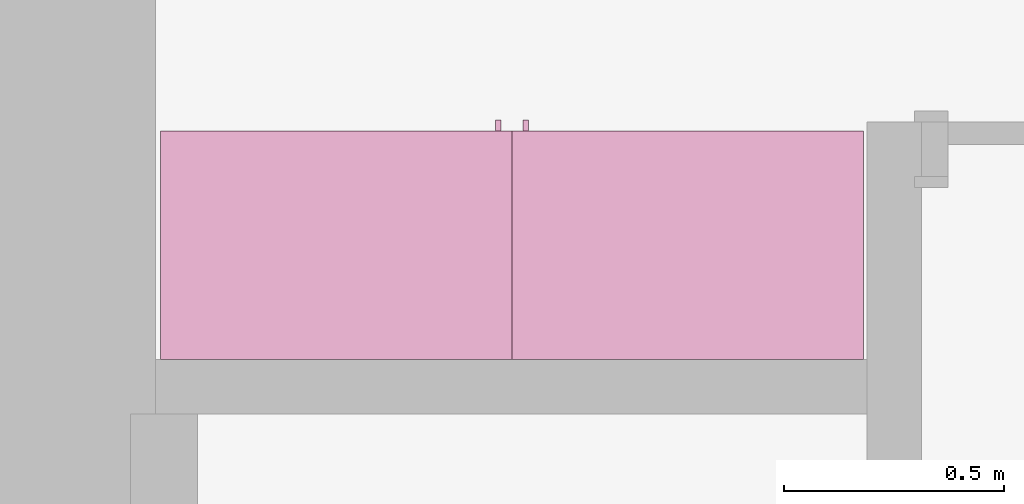
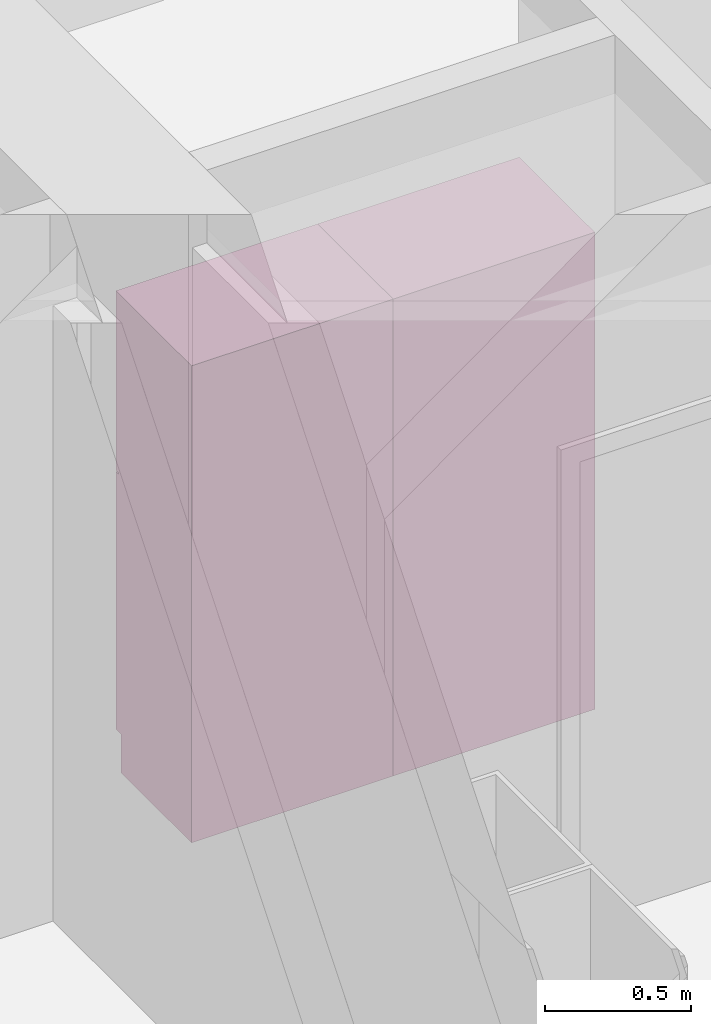
# One storey, part 16 of 16: 2 furnishings, 2 openings.
"""IFC2X3 building model written with IfcOpenShell, lengths in metres."""

from ifc_helpers import new_model, entity, si_unit, converted_unit, frame, origin, origin_2d_with_axis, place, context, project, spatial, rectangle, extrude, face_set, surface_model, source, transform, mapped, type_object, type_shapes, element, save


model = new_model("IFC2X3")

# Units and contexts
model_context = context("Model", 3, precision=1e-09, world=origin())
plan_context = context("Plan", 3, precision=1e-09, world=origin())
ifc_project = project(units=[si_unit("LENGTHUNIT", "METRE"), si_unit("AREAUNIT", "SQUARE_METRE"), si_unit("VOLUMEUNIT", "CUBIC_METRE"), converted_unit("PLANEANGLEUNIT", "DEGREE", entity("IfcRatioMeasure", 0.01745329251994328), si_unit("PLANEANGLEUNIT", "RADIAN"), dimensions=[0, 0, 0, 0, 0, 0, 0]), si_unit("TIMEUNIT", "SECOND")], contexts=[model_context, plan_context])

# Site, building, storey, space
site_placement = place(None, origin())
site = spatial("IfcSite", under=ifc_project, at=site_placement, CompositionType="ELEMENT")
building_placement = place(site_placement, origin())
building = spatial("IfcBuilding", under=site, at=building_placement, CompositionType="ELEMENT")
storey_placement = place(building_placement, frame((0.0, 0.0, 3.100000000000378)))
storey = spatial("IfcBuildingStorey", under=building, at=storey_placement, Name="Level 2", CompositionType="ELEMENT", Elevation=3.100000000000378)
space_placement = place(storey_placement, origin())
space = spatial("IfcSpace", under=storey, at=space_placement, CompositionType="ELEMENT", InteriorOrExteriorSpace="INTERNAL")

# Furnishing, opening
furniture_type_1 = type_object("IfcFurnitureType", Name="800 mm", AssemblyPlace="NOTDEFINED")
shared_shape_1 = source(origin(), model_context, "Body", "SurfaceModel", [
    surface_model("IfcFaceBasedSurfaceModel", [(0.7999999999999998, 0.04444999999999991, 0.1615874999998423), (0.0, 0.04445000000000255, 0.1615874999998423), (0.0, 0.04445000000000255, 2.0), (0.7999999999999998, 0.04444999999999991, 2.0), (0.7809499999999974, 0.04444999999999998, 1.980949999999954), (0.01904999999999817, 0.04445000000000248, 1.980949999999954), (0.01904999999999817, 0.04445000000000248, 0.1806374999998427), (0.7809499999999974, 0.04444999999999998, 0.1806374999998428), (0.0, 0.5454000000000022, 2.0), (0.8000000000000014, 0.5453999999999996, 2.0), (0.8000000000000026, 0.5453999999999996, 0.0), (0.0, 0.5454000000000009, 0.0), (0.780949999999999, 0.5453999999999996, 1.980949999999954), (0.0190499999999998, 0.5454000000000021, 1.980949999999954), (0.0190499999999998, 0.5454000000000021, 0.1806374999998428), (0.780949999999999, 0.5453999999999996, 0.1806374999998428), (0.7999999999999999, 0.06040000000000177, 0.1615874999998423), (0.7999999999999999, 0.06040000000000177, 0.0), (0.0, 0.06040000000000177, 0.0), (0.0, 0.06040000000000177, 0.1615874999998318), (0.7745999999999997, 0.0, 1.371548036695815), (0.7745999999999997, 0.0, 1.269948036695815), (0.7620677683693553, 0.0, 1.269948036695815), (0.7620677683693553, 0.0, 1.371548036695815), (0.7745999999999988, 0.0, 1.219148036695816), (0.7745999999999988, 0.0, 1.117548036695818), (0.7620677683693542, 0.0, 1.117548036695818), (0.7620677683693542, 0.0, 1.219148036695816), (0.7745999999999998, 0.02539999999999998, 1.371548036695815), (0.7745999999999998, 0.02539999999999998, 1.269948036695815), (0.7620677683693555, 0.02540000000000005, 1.269948036695815), (0.7620677683693555, 0.02540000000000005, 1.371548036695815), (0.7745999999999988, 0.02539999999999998, 1.219148036695816), (0.7745999999999988, 0.02539999999999998, 1.117548036695818), (0.7620677683693542, 0.02540000000000005, 1.117548036695818), (0.7620677683693542, 0.02540000000000005, 1.219148036695816), (0.7364999999999996, 0.03810000000000007, 1.936499999999956), (0.7364999999999996, 0.03810000000000007, 1.308048036695816), (0.06350000000000126, 0.03810000000000231, 1.308048036695816), (0.06350000000000126, 0.03810000000000231, 1.936499999999956), (0.736499999999999, 0.03810000000000007, 1.181048036695814), (0.736499999999999, 0.03810000000000007, 0.2250874999998395), (0.06350000000000072, 0.03810000000000231, 0.2250874999998395), (0.06350000000000072, 0.03810000000000231, 1.181048036695814), (0.7364999999999996, 0.04445000000000005, 1.936499999999956), (0.7364999999999996, 0.04445000000000005, 1.308048036695816), (0.06350000000000126, 0.04445000000000228, 1.308048036695816), (0.06350000000000126, 0.04445000000000228, 1.936499999999956), (0.736499999999999, 0.04445000000000005, 1.181048036695814), (0.736499999999999, 0.04445000000000005, 0.2250874999998395), (0.06350000000000072, 0.04445000000000228, 0.2250874999998395), (0.06350000000000072, 0.04445000000000228, 1.181048036695814), (0.8, 0.02539999999999984, 2.0), (0.8, 0.02539999999999984, 1.247723036695813), (0.0, 0.02540000000000248, 1.247723036695813), (0.0, 0.02540000000000248, 2.0), (0.7364999999999996, 0.02540000000000005, 1.936499999999956), (0.0635000000000012, 0.02540000000000228, 1.936499999999956), (0.0635000000000012, 0.02540000000000228, 1.308048036695816), (0.7364999999999996, 0.02540000000000005, 1.308048036695816), (0.7999999999999998, 0.02539999999999984, 0.1615874999998214), (0.0, 0.02540000000000248, 0.1615874999998214), (0.0, 0.02540000000000248, 1.241373036695815), (0.7999999999999998, 0.02539999999999984, 1.241373036695815), (0.736499999999999, 0.02540000000000005, 1.181048036695817), (0.06350000000000065, 0.02540000000000228, 1.181048036695817), (0.06350000000000065, 0.02540000000000228, 0.2250874999998395), (0.736499999999999, 0.02540000000000005, 0.2250874999998395), (0.8000000000000002, 0.04444999999999984, 2.0), (0.8000000000000002, 0.04444999999999984, 1.247723036695813), (0.0, 0.04445000000000248, 1.247723036695813), (0.0, 0.04445000000000248, 2.0), (0.7364999999999996, 0.04445000000000005, 1.936499999999956), (0.06350000000000126, 0.04445000000000228, 1.936499999999956), (0.06350000000000126, 0.04445000000000228, 1.308048036695816), (0.7364999999999996, 0.04445000000000005, 1.308048036695816), (0.7999999999999999, 0.04444999999999984, 0.1615874999998214), (0.0, 0.04445000000000248, 0.1615874999998214), (0.0, 0.04445000000000248, 1.241373036695815), (0.7999999999999999, 0.04444999999999984, 1.241373036695815), (0.736499999999999, 0.04445000000000005, 1.181048036695817), (0.06350000000000072, 0.04445000000000228, 1.181048036695817), (0.06350000000000072, 0.04445000000000228, 0.2250874999998395), (0.736499999999999, 0.04445000000000005, 0.2250874999998395), (0.7809499999999987, 0.5263500000000009, 1.980949999999952), (0.7809499999999988, 0.5263500000000009, 0.1806374999998463), (0.01904999999999987, 0.5263500000000009, 0.1806374999998463), (0.0190499999999998, 0.5263500000000009, 1.980949999999952), (0.7809499999999987, 0.5454000000000009, 1.980949999999952), (0.7809499999999987, 0.5454000000000009, 0.1806374999998463), (0.0190499999999998, 0.5454000000000009, 0.1806374999998463), (0.0190499999999998, 0.5454000000000009, 1.980949999999952)], [face_set([[[0, 1, 2, 3], [4, 5, 6, 7]], [[8, 9, 10, 11], [12, 13, 14, 15]], [[3, 0, 16, 17, 10, 9]], [[2, 8, 9, 3]], [[1, 2, 8, 11, 18, 19]], [[0, 1, 19, 16]], [[7, 15, 12, 4]], [[6, 14, 15, 7]], [[5, 13, 14, 6]], [[4, 5, 13, 12]], [[10, 17, 18, 11]], [[18, 19, 16, 17]]]), face_set([[[20, 21, 22, 23]], [[24, 25, 26, 27]], [[28, 29, 30, 31]], [[32, 33, 34, 35]], [[23, 31, 28, 20]], [[22, 23, 31, 30]], [[21, 22, 30, 29]], [[20, 28, 29, 21]], [[27, 35, 32, 24]], [[26, 27, 35, 34]], [[25, 26, 34, 33]], [[24, 32, 33, 25]]]), face_set([[[36, 37, 38, 39]], [[40, 41, 42, 43]], [[44, 45, 46, 47]], [[48, 49, 50, 51]], [[39, 47, 44, 36]], [[38, 46, 47, 39]], [[37, 38, 46, 45]], [[36, 37, 45, 44]], [[43, 51, 48, 40]], [[42, 50, 51, 43]], [[41, 42, 50, 49]], [[40, 41, 49, 48]]]), face_set([[[52, 53, 54, 55], [56, 57, 58, 59]], [[60, 61, 62, 63], [64, 65, 66, 67]], [[68, 69, 70, 71], [72, 73, 74, 75]], [[76, 77, 78, 79], [80, 81, 82, 83]], [[55, 71, 68, 52]], [[54, 55, 71, 70]], [[53, 54, 70, 69]], [[52, 53, 69, 68]], [[63, 60, 76, 79]], [[62, 78, 79, 63]], [[61, 62, 78, 77]], [[60, 61, 77, 76]], [[59, 75, 72, 56]], [[58, 74, 75, 59]], [[57, 58, 74, 73]], [[56, 57, 73, 72]], [[67, 83, 80, 64]], [[66, 82, 83, 67]], [[65, 66, 82, 81]], [[64, 65, 81, 80]]]), face_set([[[84, 85, 86, 87]], [[88, 89, 90, 91]], [[87, 91, 88, 84]], [[86, 87, 91, 90]], [[85, 86, 90, 89]], [[84, 85, 89, 88]]])]),
])
type_shapes(furniture_type_1, [shared_shape_1])
furnishing_1_placement = place(space_placement, frame((6.286000000000011, -6.120600000000008, 0.0), z_axis=(0.0, 0.0, 1.0), x_axis=(-1.0, 0.0, 0.0)))
furnishing_1 = element("IfcFurnishingElement", 1, at=furnishing_1_placement, inside=space, type_object=furniture_type_1, ObjectType="800 mm", context=model_context, shape_type="MappedRepresentation", body=[
    mapped(shared_shape_1, transform((0.0, 0.0, 0.0), scale=1.0)),
])
opening_1_placement = place(space_placement, frame((6.286000000000011, -6.120600000000008, 0.0), z_axis=(0.0, 0.0, 1.0), x_axis=(-1.0, 0.0, 0.0)))
element("IfcOpeningElement", 2, at=opening_1_placement, cuts=furnishing_1, ObjectType="Opening", context=model_context, shape_type="SweptSolid", body=[
    extrude(rectangle(XDim=1.800312500000111, YDim=0.7618999999999992, at=origin_2d_with_axis()), frame((-0.01873770491802666, 0.5009499999999996, -2.01920625000048), z_axis=(0.0, -1.0, 0.0), x_axis=(0.0, 0.0, -1.0)), (0.0, 0.0, 1.0), 0.5009499999999997),
])

furniture_type_2 = type_object("IfcFurnitureType", Name="800 mm", AssemblyPlace="NOTDEFINED")
shared_shape_2 = source(origin(), model_context, "Body", "SurfaceModel", [
    surface_model("IfcFaceBasedSurfaceModel", [(0.7999999999999998, 0.5009500000000022, 0.1615874999998423), (0.7999999999999998, 0.5009500000000022, 2.0), (0.0, 0.5009499999999997, 2.0), (0.0, 0.5009499999999997, 0.1615874999998423), (0.7809499999999974, 0.5009500000000022, 1.980949999999954), (0.7809499999999974, 0.5009500000000022, 0.1806374999998428), (0.01904999999999817, 0.5009499999999997, 0.1806374999998428), (0.01904999999999817, 0.5009499999999997, 1.980949999999954), (0.0, 0.0, 2.0), (0.0, 0.0, 0.0), (0.8000000000000026, 0.0, 0.0), (0.8000000000000014, 0.0, 2.0), (0.780949999999999, 0.0, 1.980949999999954), (0.780949999999999, 0.0, 0.1806374999998428), (0.0190499999999998, 0.0, 0.1806374999998427), (0.0190499999999998, 0.0, 1.980949999999954), (0.8000000000000026, 0.4850000000000004, 0.0), (0.7999999999999999, 0.4850000000000004, 0.1615874999998318), (0.0, 0.4850000000000004, 0.0), (0.0, 0.4850000000000004, 0.1615874999998423), (0.7745999999999997, 0.5454000000000022, 1.371548036695815), (0.7620677683693553, 0.5454000000000021, 1.371548036695815), (0.7620677683693553, 0.5454000000000021, 1.269948036695815), (0.7745999999999997, 0.5454000000000022, 1.269948036695815), (0.7745999999999988, 0.5454000000000022, 1.219148036695816), (0.7620677683693542, 0.5454000000000021, 1.219148036695816), (0.7620677683693542, 0.5454000000000021, 1.117548036695818), (0.7745999999999988, 0.5454000000000022, 1.117548036695818), (0.7745999999999998, 0.5200000000000022, 1.371548036695815), (0.7620677683693555, 0.5200000000000021, 1.371548036695815), (0.7620677683693555, 0.5200000000000021, 1.269948036695815), (0.7745999999999998, 0.5200000000000022, 1.269948036695815), (0.7745999999999988, 0.5200000000000022, 1.219148036695816), (0.7620677683693542, 0.5200000000000021, 1.219148036695816), (0.7620677683693542, 0.5200000000000021, 1.117548036695818), (0.7745999999999988, 0.5200000000000022, 1.117548036695818), (0.7364999999999996, 0.5073000000000021, 1.936499999999956), (0.06350000000000126, 0.5072999999999999, 1.936499999999956), (0.06350000000000126, 0.5072999999999999, 1.308048036695816), (0.7364999999999996, 0.5073000000000021, 1.308048036695816), (0.736499999999999, 0.5073000000000021, 1.181048036695814), (0.06350000000000072, 0.5072999999999999, 1.181048036695814), (0.06350000000000072, 0.5072999999999999, 0.2250874999998395), (0.736499999999999, 0.5073000000000021, 0.2250874999998395), (0.7364999999999996, 0.5009500000000021, 1.936499999999956), (0.06350000000000126, 0.5009499999999999, 1.936499999999956), (0.06350000000000126, 0.5009499999999999, 1.308048036695816), (0.7364999999999996, 0.5009500000000021, 1.308048036695816), (0.736499999999999, 0.5009500000000021, 1.181048036695814), (0.06350000000000072, 0.5009499999999999, 1.181048036695814), (0.06350000000000072, 0.5009499999999999, 0.2250874999998395), (0.736499999999999, 0.5009500000000021, 0.2250874999998395), (0.8, 0.5200000000000023, 2.0), (0.0, 0.5199999999999997, 2.0), (0.0, 0.5199999999999997, 1.247723036695813), (0.8, 0.5200000000000023, 1.247723036695813), (0.7364999999999996, 0.5200000000000021, 1.936499999999956), (0.7364999999999996, 0.5200000000000021, 1.308048036695816), (0.0635000000000012, 0.5199999999999999, 1.308048036695816), (0.0635000000000012, 0.5199999999999999, 1.936499999999956), (0.7999999999999998, 0.5200000000000023, 0.1615874999998214), (0.7999999999999998, 0.5200000000000023, 1.241373036695815), (0.0, 0.5199999999999997, 1.241373036695815), (0.0, 0.5199999999999997, 0.1615874999998214), (0.736499999999999, 0.5200000000000021, 1.181048036695817), (0.736499999999999, 0.5200000000000021, 0.2250874999998395), (0.06350000000000065, 0.5199999999999999, 0.2250874999998395), (0.06350000000000065, 0.5199999999999999, 1.181048036695817), (0.8000000000000002, 0.5009500000000023, 2.0), (0.0, 0.5009499999999997, 2.0), (0.0, 0.5009499999999997, 1.247723036695813), (0.8, 0.5009500000000023, 1.247723036695813), (0.7364999999999996, 0.5009500000000021, 1.936499999999956), (0.7364999999999996, 0.5009500000000021, 1.308048036695816), (0.06350000000000126, 0.5009499999999999, 1.308048036695816), (0.06350000000000126, 0.5009499999999999, 1.936499999999956), (0.7999999999999999, 0.5009500000000023, 0.1615874999998214), (0.7999999999999999, 0.5009500000000023, 1.241373036695815), (0.0, 0.5009499999999997, 1.241373036695815), (0.0, 0.5009499999999997, 0.1615874999998214), (0.736499999999999, 0.5009500000000021, 1.181048036695817), (0.736499999999999, 0.5009500000000021, 0.2250874999998395), (0.06350000000000072, 0.5009499999999999, 0.2250874999998395), (0.06350000000000072, 0.5009499999999999, 1.181048036695817), (0.7809499999999987, 0.01905000000000129, 1.980949999999952), (0.0190499999999998, 0.01905000000000129, 1.980949999999952), (0.0190499999999998, 0.01905000000000129, 0.1806374999998463), (0.7809499999999987, 0.01905000000000129, 0.1806374999998463), (0.7809499999999987, 0.0, 1.980949999999952), (0.0190499999999998, 0.0, 1.980949999999952), (0.01904999999999987, 0.0, 0.1806374999998463), (0.7809499999999988, 0.0, 0.1806374999998463)], [face_set([[[0, 1, 2, 3], [4, 5, 6, 7]], [[8, 9, 10, 11], [12, 13, 14, 15]], [[1, 11, 10, 16, 17, 0]], [[2, 1, 11, 8]], [[3, 2, 8, 9, 18, 19]], [[0, 17, 19, 3]], [[5, 4, 12, 13]], [[6, 5, 13, 14]], [[7, 6, 14, 15]], [[4, 12, 15, 7]], [[10, 9, 18, 16]], [[18, 16, 17, 19]]]), face_set([[[20, 21, 22, 23]], [[24, 25, 26, 27]], [[28, 29, 30, 31]], [[32, 33, 34, 35]], [[21, 20, 28, 29]], [[22, 30, 29, 21]], [[23, 31, 30, 22]], [[20, 23, 31, 28]], [[25, 24, 32, 33]], [[26, 34, 33, 25]], [[27, 35, 34, 26]], [[24, 27, 35, 32]]]), face_set([[[36, 37, 38, 39]], [[40, 41, 42, 43]], [[44, 45, 46, 47]], [[48, 49, 50, 51]], [[37, 36, 44, 45]], [[38, 37, 45, 46]], [[39, 47, 46, 38]], [[36, 44, 47, 39]], [[41, 40, 48, 49]], [[42, 41, 49, 50]], [[43, 51, 50, 42]], [[40, 48, 51, 43]]]), face_set([[[52, 53, 54, 55], [56, 57, 58, 59]], [[60, 61, 62, 63], [64, 65, 66, 67]], [[68, 69, 70, 71], [72, 73, 74, 75]], [[76, 77, 78, 79], [80, 81, 82, 83]], [[53, 52, 68, 69]], [[54, 70, 69, 53]], [[55, 71, 70, 54]], [[52, 68, 71, 55]], [[61, 77, 76, 60]], [[62, 61, 77, 78]], [[63, 79, 78, 62]], [[60, 76, 79, 63]], [[57, 56, 72, 73]], [[58, 57, 73, 74]], [[59, 75, 74, 58]], [[56, 72, 75, 59]], [[65, 64, 80, 81]], [[66, 65, 81, 82]], [[67, 83, 82, 66]], [[64, 80, 83, 67]]]), face_set([[[84, 85, 86, 87]], [[88, 89, 90, 91]], [[85, 84, 88, 89]], [[86, 90, 89, 85]], [[87, 91, 90, 86]], [[84, 88, 91, 87]]])]),
])
type_shapes(furniture_type_2, [shared_shape_2])
furnishing_2_placement = place(space_placement, frame((4.686000000000006, -6.665999999999998, 0.0)))
furnishing_2 = element("IfcFurnishingElement", 3, at=furnishing_2_placement, inside=space, type_object=furniture_type_2, ObjectType="800 mm", context=model_context, shape_type="MappedRepresentation", body=[
    mapped(shared_shape_2, transform((0.0, 0.0, 0.0), scale=1.0)),
])
opening_2_placement = place(space_placement, frame((4.686000000000006, -6.665999999999998, 0.0)))
element("IfcOpeningElement", 4, at=opening_2_placement, cuts=furnishing_2, ObjectType="Opening", context=model_context, shape_type="SweptSolid", body=[
    extrude(rectangle(XDim=1.800312500000111, YDim=0.7618999999999992, at=origin_2d_with_axis()), frame((0.01873770491802511, 0.0, -2.01920625000048), z_axis=(0.0, 1.0, 0.0), x_axis=(0.0, 0.0, -1.0)), (0.0, 0.0, 1.0), 0.5009499999999997),
])

save(model, "model.ifc")
